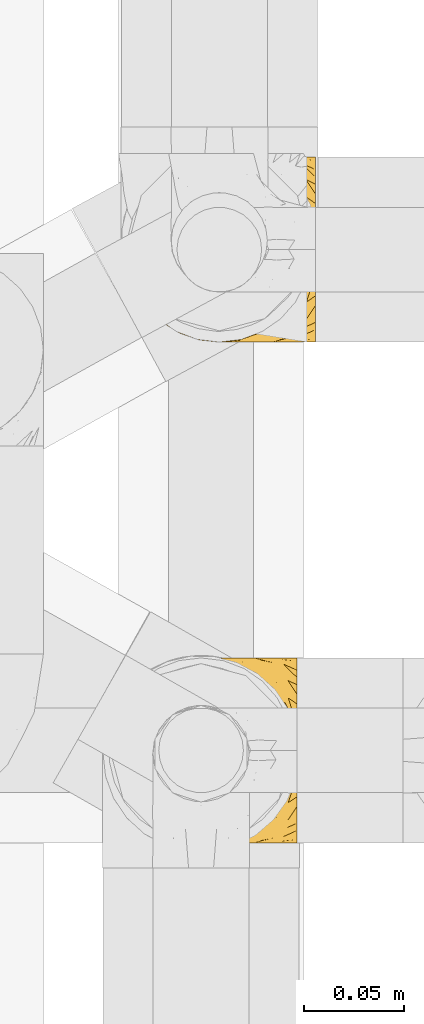
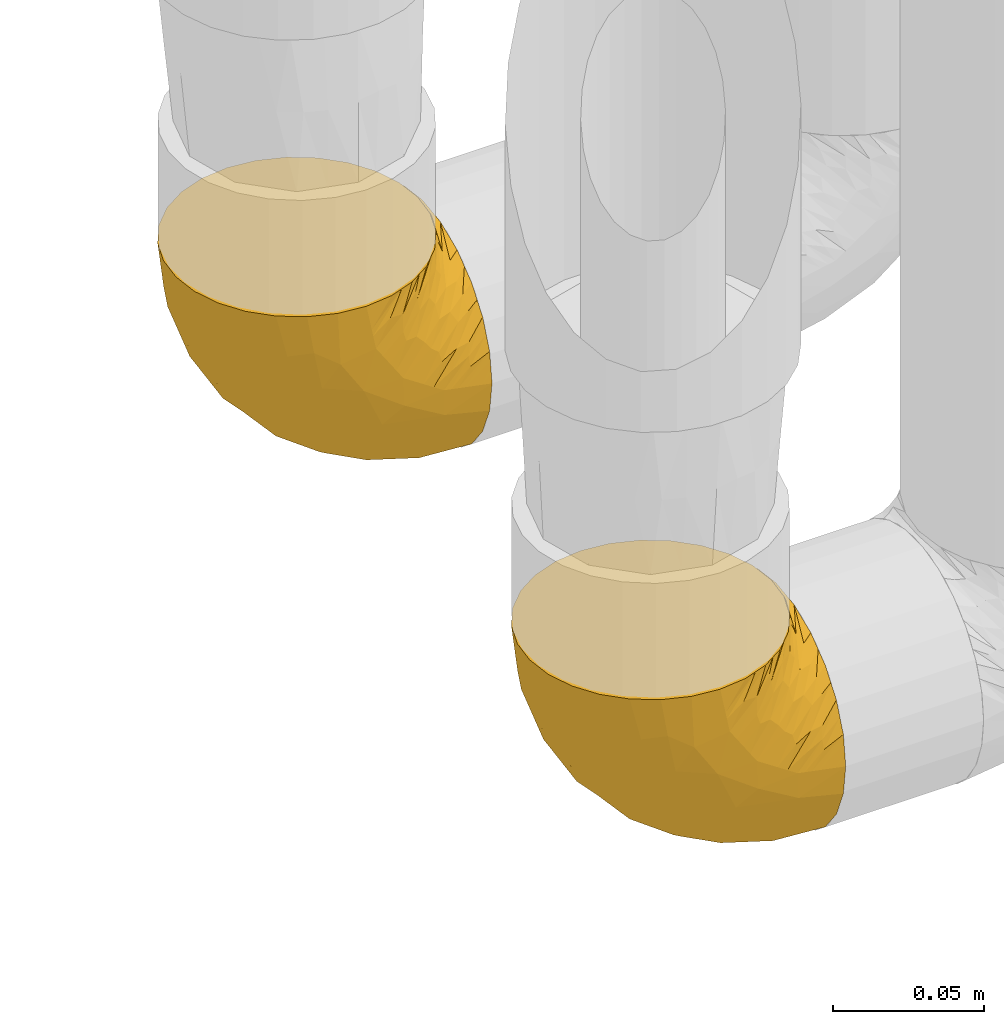
# One storey, part 174 of 827: 2 coverings.
"""IFC2X3 building model written with IfcOpenShell, lengths in millimetres."""

from ifc_helpers import new_model, entity, si_unit, converted_unit, derived_unit, direction, frame, origin, place, context, subcontext, project, spatial, faceted_brep, element, save


model = new_model("IFC2X3")

# Units and contexts
model_context = context("Model", 3, precision=0.01, world=origin(), true_north=direction((6.12303176911189e-17, 1.0)))
body_context = subcontext(model_context, "Body", "Model", "MODEL_VIEW")
ifc_project = project(units=[si_unit("LENGTHUNIT", "METRE", prefix="MILLI"), si_unit("AREAUNIT", "SQUARE_METRE"), si_unit("VOLUMEUNIT", "CUBIC_METRE"), converted_unit("PLANEANGLEUNIT", "DEGREE", entity("IfcRatioMeasure", 0.0174532925199433), si_unit("PLANEANGLEUNIT", "RADIAN"), dimensions=[0, 0, 0, 0, 0, 0, 0]), si_unit("MASSUNIT", "GRAM", prefix="KILO"), derived_unit("MASSDENSITYUNIT", [(si_unit("MASSUNIT", "GRAM", prefix="KILO"), 1), (si_unit("LENGTHUNIT", "METRE"), -3)]), derived_unit("MOMENTOFINERTIAUNIT", [(si_unit("LENGTHUNIT", "METRE"), 4)]), si_unit("TIMEUNIT", "SECOND"), si_unit("FREQUENCYUNIT", "HERTZ"), si_unit("THERMODYNAMICTEMPERATUREUNIT", "DEGREE_CELSIUS"), derived_unit("THERMALTRANSMITTANCEUNIT", [(si_unit("MASSUNIT", "GRAM", prefix="KILO"), 1), (si_unit("THERMODYNAMICTEMPERATUREUNIT", "KELVIN"), -1), (si_unit("TIMEUNIT", "SECOND"), -3)]), derived_unit("VOLUMETRICFLOWRATEUNIT", [(si_unit("LENGTHUNIT", "METRE"), 3), (si_unit("TIMEUNIT", "SECOND"), -1)]), derived_unit("MASSFLOWRATEUNIT", [(si_unit("MASSUNIT", "GRAM", prefix="KILO"), 1), (si_unit("TIMEUNIT", "SECOND"), -1)]), derived_unit("ROTATIONALFREQUENCYUNIT", [(si_unit("TIMEUNIT", "SECOND"), -1)]), si_unit("ELECTRICCURRENTUNIT", "AMPERE"), si_unit("ELECTRICVOLTAGEUNIT", "VOLT"), si_unit("POWERUNIT", "WATT"), si_unit("FORCEUNIT", "NEWTON", prefix="KILO"), si_unit("ILLUMINANCEUNIT", "LUX"), si_unit("LUMINOUSFLUXUNIT", "LUMEN"), si_unit("LUMINOUSINTENSITYUNIT", "CANDELA"), derived_unit("USERDEFINED", [(si_unit("MASSUNIT", "GRAM", prefix="KILO"), -1), (si_unit("LENGTHUNIT", "METRE"), -2), (si_unit("TIMEUNIT", "SECOND"), 3), (si_unit("LUMINOUSFLUXUNIT", "LUMEN"), 1)]), derived_unit("LINEARVELOCITYUNIT", [(si_unit("LENGTHUNIT", "METRE"), 1), (si_unit("TIMEUNIT", "SECOND"), -1)]), si_unit("PRESSUREUNIT", "PASCAL"), derived_unit("USERDEFINED", [(si_unit("LENGTHUNIT", "METRE"), -2), (si_unit("MASSUNIT", "GRAM", prefix="KILO"), 1), (si_unit("TIMEUNIT", "SECOND"), -2)]), derived_unit("LINEARFORCEUNIT", [(si_unit("MASSUNIT", "GRAM", prefix="KILO"), 1), (si_unit("LENGTHUNIT", "METRE"), 1), (si_unit("TIMEUNIT", "SECOND"), -2), (si_unit("LENGTHUNIT", "METRE"), -1)]), derived_unit("PLANARFORCEUNIT", [(si_unit("MASSUNIT", "GRAM", prefix="KILO"), 1), (si_unit("LENGTHUNIT", "METRE"), 1), (si_unit("TIMEUNIT", "SECOND"), -2), (si_unit("LENGTHUNIT", "METRE"), -2)])], contexts=[model_context])

# Site, building, storey
site_placement = place(None, origin())
site = spatial("IfcSite", under=ifc_project, at=site_placement, CompositionType="ELEMENT")
building_placement = place(site_placement, origin())
building = spatial("IfcBuilding", under=site, at=building_placement, CompositionType="ELEMENT")
storey_placement = place(building_placement, frame((0.0, 0.0, 28200.0)))
storey = spatial("IfcBuildingStorey", under=building, at=storey_placement, Name="08", CompositionType="ELEMENT", Elevation=28200.0)

# Coverings
covering_1_placement = place(storey_placement, frame((35677.24, 12708.37, 352.2)))
element("IfcCovering", 1, at=covering_1_placement, inside=storey, Name=":ADSK_", ObjectType=":ADSK_", PredefinedType="INSULATION", context=body_context, shape_type="Brep", body=[
    faceted_brep([(18.98, 83.91, 95.8), (11.67, 76.59, 95.8), (6.17, 67.83, 95.8), (2.75, 58.07, 95.8), (1.6, 47.8, 95.8), (2.75, 37.51, 95.8), (6.17, 27.74, 95.8), (11.68, 18.98, 95.8), (19.0, 11.67, 95.8), (27.76, 6.17, 95.8), (37.52, 2.75, 95.8), (47.8, 1.6, 95.8), (51.94, 2.06, 95.8), (55.01, 2.41, 95.8), (58.08, 2.75, 95.8), (62.96, 4.46, 95.8), (67.85, 6.17, 95.8), (72.23, 8.93, 95.8), (76.61, 11.68, 95.8), (80.26, 15.34, 95.8), (83.92, 19.0, 95.8), (89.42, 27.76, 95.8), (91.13, 32.64, 95.8), (92.84, 37.52, 95.8), (94.0, 47.8, 95.8), (92.84, 58.08, 95.8), (91.13, 62.96, 95.8), (89.42, 67.85, 95.8), (83.91, 76.61, 95.8), (80.25, 80.26, 95.8), (76.59, 83.92, 95.8), (72.21, 86.67, 95.8), (67.83, 89.42, 95.8), (62.95, 91.13, 95.8), (58.07, 92.84, 95.8), (55.0, 93.18, 95.8), (51.94, 93.53, 95.8), (47.8, 94.0, 95.8), (37.51, 92.84, 95.8), (27.74, 89.42, 95.8), (95.8, 47.8, 94.0), (95.8, 35.84, 92.42), (95.8, 24.7, 87.81), (95.8, 19.91, 84.13), (95.8, 15.13, 80.46), (95.8, 11.46, 75.68), (95.8, 7.78, 70.9), (95.8, 5.48, 65.32), (95.8, 3.17, 59.75), (95.8, 2.69, 56.14), (95.8, 2.42, 54.06), (95.8, 2.14, 51.97), (95.8, 1.6, 47.8), (95.8, 3.17, 35.84), (95.8, 7.78, 24.7), (95.8, 15.13, 15.13), (95.8, 24.7, 7.78), (95.8, 35.84, 3.17), (95.8, 47.8, 1.6), (95.8, 59.75, 3.17), (95.8, 70.9, 7.78), (95.8, 80.46, 15.13), (95.8, 87.81, 24.7), (95.8, 92.42, 35.84), (95.8, 94.0, 47.8), (95.8, 93.45, 51.97), (95.8, 92.9, 56.14), (95.8, 92.42, 59.75), (95.8, 90.11, 65.32), (95.8, 87.81, 70.9), (95.8, 84.13, 75.68), (95.8, 80.46, 80.46), (95.8, 75.68, 84.13), (95.8, 70.9, 87.81), (95.8, 59.75, 92.42), (60.58, 71.98, 15.84), (74.11, 63.6, 6.99), (51.59, 59.72, 14.39), (66.69, 47.8, 6.21), (76.19, 55.16, 4.26), (84.43, 47.8, 3.39), (31.2, 63.76, 31.2), (42.88, 72.22, 26.47), (79.41, 74.18, 11.44), (60.7, 92.52, 47.66), (61.85, 94.0, 61.85), (65.75, 94.0, 59.25), (69.64, 94.0, 56.65), (73.53, 94.0, 54.05), (77.43, 94.0, 51.45), (74.59, 82.14, 19.8), (54.72, 80.34, 26.22), (64.18, 87.52, 31.58), (37.94, 79.59, 38.36), (25.89, 78.25, 51.54), (34.73, 85.01, 51.6), (42.89, 90.25, 55.97), (49.83, 93.2, 62.88), (48.58, 87.23, 41.35), (22.41, 85.55, 82.24), (78.69, 93.0, 40.88), (81.64, 89.31, 29.0), (6.22, 61.31, 74.06), (12.11, 56.86, 54.53), (14.81, 68.34, 57.98), (21.61, 65.71, 43.81), (22.41, 56.99, 38.22), (30.12, 72.15, 38.33), (10.01, 70.34, 74.76), (15.36, 78.36, 76.85), (3.39, 47.8, 84.43), (19.59, 47.8, 40.43), (30.01, 47.8, 30.01), (41.19, 93.06, 78.67), (48.54, 94.0, 92.06), (49.28, 94.0, 88.32), (49.82, 94.0, 85.6), (50.37, 94.0, 82.88), (50.91, 94.0, 80.15), (51.45, 94.0, 77.43), (31.61, 89.88, 76.36), (80.15, 94.0, 50.91), (82.88, 94.0, 50.37), (85.6, 94.0, 49.82), (88.32, 94.0, 49.28), (90.19, 94.0, 48.91), (92.06, 94.0, 48.54), (6.21, 47.8, 66.69), (54.05, 94.0, 73.53), (56.65, 94.0, 69.64), (59.25, 94.0, 65.75), (24.66, 83.7, 66.13), (40.43, 47.8, 19.59), (35.17, 55.9, 24.64), (12.9, 47.8, 53.56), (53.56, 47.8, 12.9), (85.34, 81.75, 82.81), (78.44, 86.43, 81.22), (84.37, 79.8, 86.57), (89.05, 69.84, 92.75), (82.76, 79.5, 89.68), (86.31, 88.08, 72.26), (83.73, 91.6, 64.73), (77.31, 92.93, 62.45), (87.78, 92.43, 60.63), (87.91, 93.24, 56.91), (81.29, 93.36, 58.14), (93.97, 57.25, 93.7), (70.76, 89.41, 83.4), (63.67, 92.89, 75.54), (62.62, 92.66, 79.46), (90.64, 79.58, 82.28), (84.08, 86.51, 76.25), (76.28, 86.29, 84.69), (77.45, 83.91, 90.18), (88.72, 90.94, 65.12), (71.28, 91.94, 71.71), (68.09, 91.98, 75.21), (91.07, 82.79, 78.6), (57.47, 93.16, 87.27), (70.34, 88.76, 87.92), (91.35, 73.94, 86.94), (62.99, 91.89, 86.1), (94.52, 47.8, 94.52), (76.47, 92.22, 66.23), (69.96, 88.56, 91.08), (89.86, 87.72, 71.77), (78.94, 88.33, 76.21), (73.51, 92.18, 68.59), (89.62, 71.78, 89.94), (84.09, 9.09, 76.25), (86.3, 7.51, 72.26), (91.06, 12.8, 78.6), (88.32, 1.6, 49.28), (92.06, 1.6, 48.54), (82.88, 1.6, 50.37), (85.6, 1.6, 49.82), (93.97, 38.35, 93.7), (89.63, 23.84, 89.95), (50.37, 1.6, 82.88), (49.82, 1.6, 85.6), (48.54, 1.6, 92.06), (49.28, 1.6, 88.32), (82.77, 16.1, 89.68), (70.36, 6.84, 87.92), (77.31, 2.66, 62.45), (76.47, 3.37, 66.24), (69.64, 1.6, 56.65), (65.75, 1.6, 59.25), (87.78, 3.16, 60.63), (87.91, 2.35, 56.91), (89.06, 25.77, 92.76), (90.65, 16.02, 82.28), (85.35, 13.85, 82.81), (73.53, 1.6, 54.05), (77.43, 1.6, 51.45), (81.29, 2.23, 58.14), (77.46, 11.69, 90.18), (76.29, 9.31, 84.7), (57.47, 2.43, 87.25), (63.71, 2.71, 75.58), (68.11, 3.61, 75.2), (70.77, 6.18, 83.39), (71.31, 3.66, 71.7), (78.46, 9.17, 81.22), (69.52, 6.77, 90.73), (62.64, 2.93, 79.47), (91.35, 21.66, 86.94), (59.25, 1.6, 65.75), (84.6, 16.09, 86.75), (62.98, 3.7, 86.08), (51.45, 1.6, 77.43), (54.05, 1.6, 73.53), (56.65, 1.6, 69.64), (83.73, 3.99, 64.73), (80.15, 1.6, 50.91), (88.72, 4.65, 65.12), (61.85, 1.6, 61.85), (73.56, 3.43, 68.62), (78.96, 7.27, 76.22), (91.36, 9.46, 74.03), (50.91, 1.6, 80.15), (62.87, 2.4, 49.81), (76.19, 40.43, 4.26), (73.57, 13.57, 19.95), (56.07, 11.3, 30.61), (49.77, 18.65, 25.71), (44.73, 27.26, 22.43), (60.58, 23.61, 15.85), (47.64, 3.07, 60.69), (78.32, 2.69, 40.49), (51.59, 35.87, 14.39), (74.11, 31.99, 6.99), (76.04, 6.71, 29.56), (79.41, 21.41, 11.45), (14.82, 27.24, 57.98), (6.22, 34.26, 74.06), (12.12, 38.73, 54.52), (23.51, 26.97, 43.47), (31.2, 31.83, 31.2), (34.96, 23.4, 33.27), (33.86, 6.91, 64.26), (38.94, 3.4, 74.29), (30.23, 5.84, 80.41), (35.17, 39.69, 24.64), (15.85, 17.6, 73.62), (22.59, 10.38, 78.98), (21.56, 20.6, 53.69), (55.94, 5.36, 42.86), (20.67, 35.73, 41.67), (9.19, 24.84, 79.66), (25.79, 13.87, 58.41), (41.16, 9.06, 47.11), (37.95, 15.99, 38.37)], [[[0, 1, 2, 3, 4, 5, 6, 7, 8, 9, 10, 11, 12, 13, 14, 15, 16, 17, 18, 19, 20, 21, 22, 23, 24, 25, 26, 27, 28, 29, 30, 31, 32, 33, 34, 35, 36, 37, 38, 39]], [[40, 41, 42, 43, 44, 45, 46, 47, 48, 49, 50, 51, 52, 53, 54, 55, 56, 57, 58, 59, 60, 61, 62, 63, 64, 65, 66, 67, 68, 69, 70, 71, 72, 73, 74]], [[75, 76, 77]], [[78, 79, 80]], [[77, 81, 82]], [[76, 75, 83]], [[84, 85, 86, 87, 88, 89]], [[90, 91, 92]], [[76, 60, 59]], [[93, 94, 95]], [[90, 62, 61]], [[83, 61, 60]], [[96, 97, 84]], [[98, 93, 95]], [[0, 39, 99]], [[100, 84, 89]], [[62, 101, 63]], [[2, 102, 3]], [[92, 84, 100]], [[103, 102, 104]], [[103, 105, 106]], [[93, 107, 94]], [[1, 108, 2]], [[92, 101, 90]], [[108, 1, 109]], [[102, 110, 3]], [[93, 82, 107]], [[102, 108, 104]], [[111, 106, 112]], [[109, 0, 99]], [[113, 37, 114, 115, 116, 117, 118, 119]], [[120, 38, 113]], [[100, 89, 121, 122, 123, 124, 125, 126, 64]], [[127, 102, 103]], [[97, 119, 128, 129, 130, 85]], [[99, 120, 131]], [[132, 133, 77]], [[59, 80, 79]], [[1, 0, 109]], [[98, 84, 92]], [[94, 109, 131]], [[120, 39, 38]], [[93, 91, 82]], [[104, 94, 105]], [[97, 113, 119]], [[95, 120, 96]], [[83, 90, 61]], [[91, 93, 98]], [[64, 63, 100]], [[100, 63, 101]], [[77, 76, 79]], [[133, 106, 81]], [[84, 97, 85]], [[113, 96, 120]], [[113, 97, 96]], [[37, 113, 38]], [[110, 102, 127]], [[110, 4, 3]], [[103, 111, 134, 127]], [[90, 75, 91]], [[82, 81, 107]], [[91, 75, 82]], [[77, 82, 75]], [[76, 83, 60]], [[90, 83, 75]], [[105, 107, 81]], [[94, 131, 95]], [[105, 94, 107]], [[109, 94, 104]], [[120, 95, 131]], [[98, 95, 96]], [[84, 98, 96]], [[98, 92, 91]], [[106, 105, 81]], [[103, 104, 105]], [[112, 106, 133]], [[103, 106, 111]], [[112, 133, 132]], [[81, 77, 133]], [[77, 78, 135, 132]], [[120, 99, 39]], [[109, 99, 131]], [[59, 58, 80]], [[59, 79, 76]], [[90, 101, 62]], [[100, 101, 92]], [[2, 108, 102]], [[109, 104, 108]], [[78, 77, 79]], [[136, 137, 138]], [[27, 139, 140]], [[141, 142, 143]], [[144, 145, 121]], [[146, 89, 88]], [[147, 139, 25]], [[148, 149, 150]], [[136, 151, 152]], [[147, 40, 74]], [[24, 147, 25]], [[140, 153, 154]], [[33, 116, 34]], [[73, 72, 151]], [[114, 37, 36, 35, 34, 116, 115]], [[146, 155, 144]], [[156, 85, 130]], [[157, 149, 148]], [[151, 158, 152]], [[117, 33, 159]], [[29, 154, 160]], [[161, 74, 73]], [[162, 128, 119]], [[66, 65, 64, 126, 125, 124, 123, 122, 67]], [[163, 147, 24]], [[27, 140, 28]], [[149, 129, 150]], [[139, 27, 26, 25]], [[68, 144, 69]], [[129, 128, 150]], [[164, 87, 86]], [[130, 129, 149]], [[122, 145, 67]], [[154, 153, 148]], [[162, 119, 159]], [[165, 30, 160]], [[150, 160, 148]], [[128, 162, 150]], [[30, 165, 31]], [[145, 144, 68]], [[89, 146, 144]], [[87, 164, 143]], [[166, 155, 142]], [[88, 87, 143]], [[162, 160, 150]], [[160, 30, 29]], [[154, 29, 28]], [[140, 154, 28]], [[160, 154, 148]], [[140, 137, 153]], [[157, 148, 153]], [[156, 130, 157]], [[153, 137, 157]], [[157, 137, 156]], [[167, 137, 136]], [[168, 85, 156]], [[152, 168, 167]], [[167, 168, 156]], [[164, 152, 141]], [[71, 158, 72]], [[152, 167, 136]], [[88, 142, 146]], [[144, 155, 69]], [[146, 142, 155]], [[70, 166, 71]], [[142, 141, 166]], [[70, 69, 155]], [[141, 158, 71]], [[161, 73, 151]], [[138, 137, 140]], [[161, 136, 169]], [[136, 161, 151]], [[74, 161, 169]], [[152, 158, 141]], [[151, 72, 158]], [[168, 152, 164]], [[137, 167, 156]], [[164, 86, 168]], [[85, 168, 86]], [[116, 33, 117]], [[130, 149, 157]], [[67, 145, 68]], [[121, 89, 144]], [[145, 122, 121]], [[40, 147, 163]], [[169, 147, 74]], [[159, 33, 32]], [[162, 159, 32]], [[159, 119, 118, 117]], [[139, 147, 169]], [[139, 169, 138]], [[162, 32, 31]], [[141, 143, 164]], [[88, 143, 142]], [[71, 166, 141]], [[155, 166, 70]], [[139, 138, 140]], [[169, 136, 138]], [[160, 162, 165]], [[162, 31, 165]], [[170, 171, 172]], [[173, 174, 52, 51, 50, 49, 48, 175, 176]], [[177, 178, 41]], [[179, 15, 180]], [[12, 11, 181, 182, 180, 14, 13]], [[183, 21, 20]], [[19, 18, 184]], [[185, 186, 187]], [[186, 188, 187]], [[43, 172, 44]], [[189, 190, 47]], [[23, 22, 21, 191]], [[170, 192, 193]], [[40, 163, 177]], [[194, 195, 196]], [[24, 23, 177]], [[197, 198, 183]], [[199, 15, 179]], [[47, 46, 189]], [[200, 201, 202]], [[201, 203, 204]], [[205, 206, 184]], [[207, 41, 178]], [[16, 15, 199]], [[14, 180, 15]], [[202, 201, 198]], [[208, 201, 200]], [[163, 24, 177]], [[48, 47, 190]], [[196, 195, 189]], [[197, 184, 202]], [[204, 193, 209]], [[210, 211, 212]], [[206, 212, 213]], [[205, 17, 210]], [[184, 206, 202]], [[210, 212, 206]], [[185, 194, 214]], [[189, 215, 190]], [[216, 45, 214]], [[186, 171, 170]], [[189, 216, 196]], [[197, 20, 19]], [[194, 185, 187]], [[197, 183, 20]], [[184, 197, 19]], [[197, 202, 198]], [[206, 200, 202]], [[204, 183, 198]], [[201, 208, 203]], [[203, 208, 217]], [[204, 198, 201]], [[217, 188, 218]], [[193, 219, 170]], [[171, 186, 185]], [[170, 218, 186]], [[170, 219, 218]], [[42, 207, 192]], [[171, 220, 172]], [[216, 189, 46]], [[214, 194, 196]], [[44, 220, 45]], [[214, 196, 216]], [[216, 46, 45]], [[214, 45, 220]], [[192, 43, 42]], [[204, 203, 219]], [[207, 193, 192]], [[209, 193, 178]], [[41, 207, 42]], [[193, 207, 178]], [[43, 192, 172]], [[170, 172, 192]], [[204, 219, 193]], [[219, 203, 218]], [[217, 218, 203]], [[188, 186, 218]], [[206, 213, 200]], [[208, 200, 213]], [[199, 210, 16]], [[215, 189, 195]], [[215, 175, 190]], [[175, 48, 190]], [[199, 179, 221, 211]], [[210, 199, 211]], [[23, 191, 177]], [[40, 177, 41]], [[178, 177, 191]], [[21, 183, 191]], [[209, 191, 183]], [[205, 18, 17]], [[17, 16, 210]], [[171, 185, 214]], [[172, 220, 44]], [[214, 220, 171]], [[191, 209, 178]], [[204, 209, 183]], [[206, 205, 210]], [[18, 205, 184]], [[222, 195, 194, 187, 188, 217]], [[57, 223, 80]], [[224, 225, 226]], [[226, 227, 228]], [[229, 217, 208, 213, 212, 211]], [[230, 52, 174, 173, 176, 175, 215, 195]], [[231, 232, 228]], [[231, 78, 223]], [[223, 57, 232]], [[224, 233, 225]], [[233, 54, 53]], [[234, 232, 56]], [[56, 55, 234]], [[234, 224, 228]], [[235, 236, 237]], [[224, 55, 54]], [[238, 239, 240]], [[52, 230, 53]], [[241, 242, 243]], [[227, 244, 231]], [[11, 10, 242]], [[236, 6, 5]], [[7, 245, 8]], [[8, 246, 9]], [[238, 247, 235]], [[222, 229, 248]], [[242, 211, 221, 179, 180, 182, 181, 11]], [[233, 53, 230]], [[111, 112, 249]], [[250, 6, 236]], [[246, 251, 241]], [[6, 250, 7]], [[127, 236, 110]], [[248, 229, 252]], [[246, 8, 245]], [[235, 245, 250]], [[236, 5, 110]], [[235, 249, 238]], [[237, 236, 127]], [[243, 9, 246]], [[252, 229, 241]], [[56, 232, 57]], [[222, 230, 195]], [[225, 248, 252]], [[248, 233, 230]], [[54, 233, 224]], [[231, 228, 227]], [[244, 132, 231]], [[248, 225, 233]], [[226, 225, 253]], [[235, 250, 236]], [[245, 7, 250]], [[251, 246, 245]], [[243, 246, 241]], [[247, 245, 235]], [[252, 251, 253]], [[229, 222, 217]], [[230, 222, 248]], [[5, 4, 110]], [[237, 127, 134, 111]], [[238, 249, 239]], [[224, 234, 55]], [[232, 234, 228]], [[242, 241, 229]], [[10, 9, 243]], [[211, 242, 229]], [[10, 243, 242]], [[80, 223, 78]], [[80, 58, 57]], [[231, 223, 232]], [[227, 240, 239]], [[224, 226, 228]], [[240, 226, 253]], [[227, 239, 244]], [[226, 240, 227]], [[251, 247, 253]], [[240, 253, 247]], [[249, 235, 237]], [[237, 111, 249]], [[112, 132, 244]], [[112, 244, 249]], [[78, 231, 132, 135]], [[249, 244, 239]], [[247, 238, 240]], [[245, 247, 251]], [[251, 252, 241]], [[225, 252, 253]]]),
])
covering_2_placement = place(storey_placement, frame((35686.34, 12958.41, 352.2)))
element("IfcCovering", 2, at=covering_2_placement, inside=storey, Name=":ADSK_", ObjectType=":ADSK_", PredefinedType="INSULATION", context=body_context, shape_type="Brep", body=[
    faceted_brep([(18.98, 83.91, 95.8), (11.67, 76.59, 95.8), (6.17, 67.83, 95.8), (2.75, 58.07, 95.8), (1.6, 47.8, 95.8), (2.75, 37.51, 95.8), (6.17, 27.74, 95.8), (11.68, 18.98, 95.8), (19.0, 11.67, 95.8), (27.76, 6.17, 95.8), (37.52, 2.75, 95.8), (47.8, 1.6, 95.8), (51.94, 2.06, 95.8), (55.01, 2.41, 95.8), (58.08, 2.75, 95.8), (62.96, 4.46, 95.8), (67.85, 6.17, 95.8), (72.23, 8.93, 95.8), (76.61, 11.68, 95.8), (80.26, 15.34, 95.8), (83.92, 19.0, 95.8), (89.42, 27.76, 95.8), (91.13, 32.64, 95.8), (92.84, 37.52, 95.8), (94.0, 47.8, 95.8), (92.84, 58.08, 95.8), (91.13, 62.96, 95.8), (89.42, 67.85, 95.8), (83.91, 76.61, 95.8), (80.25, 80.26, 95.8), (76.59, 83.92, 95.8), (72.21, 86.67, 95.8), (67.83, 89.42, 95.8), (62.95, 91.13, 95.8), (58.07, 92.84, 95.8), (55.0, 93.18, 95.8), (51.94, 93.53, 95.8), (47.8, 94.0, 95.8), (37.51, 92.84, 95.8), (27.74, 89.42, 95.8), (95.8, 47.8, 94.0), (95.8, 35.84, 92.42), (95.8, 24.7, 87.81), (95.8, 19.91, 84.13), (95.8, 15.13, 80.46), (95.8, 11.46, 75.68), (95.8, 7.78, 70.9), (95.8, 5.48, 65.32), (95.8, 3.17, 59.75), (95.8, 2.69, 56.14), (95.8, 2.42, 54.06), (95.8, 2.14, 51.97), (95.8, 1.6, 47.8), (95.8, 3.17, 35.84), (95.8, 7.78, 24.7), (95.8, 15.13, 15.13), (95.8, 24.7, 7.78), (95.8, 35.84, 3.17), (95.8, 47.8, 1.6), (95.8, 59.75, 3.17), (95.8, 70.9, 7.78), (95.8, 80.46, 15.13), (95.8, 87.81, 24.7), (95.8, 92.42, 35.84), (95.8, 94.0, 47.8), (95.8, 93.45, 51.97), (95.8, 92.9, 56.14), (95.8, 92.42, 59.75), (95.8, 90.11, 65.32), (95.8, 87.81, 70.9), (95.8, 84.13, 75.68), (95.8, 80.46, 80.46), (95.8, 75.68, 84.13), (95.8, 70.9, 87.81), (95.8, 59.75, 92.42), (60.58, 71.98, 15.84), (74.11, 63.6, 6.99), (51.59, 59.72, 14.39), (66.69, 47.8, 6.21), (76.19, 55.16, 4.26), (84.43, 47.8, 3.39), (31.2, 63.76, 31.2), (42.88, 72.22, 26.47), (79.41, 74.18, 11.44), (60.7, 92.52, 47.66), (61.85, 94.0, 61.85), (65.75, 94.0, 59.25), (69.64, 94.0, 56.65), (73.53, 94.0, 54.05), (77.43, 94.0, 51.45), (74.59, 82.14, 19.8), (54.72, 80.34, 26.22), (64.18, 87.52, 31.58), (37.94, 79.59, 38.36), (25.89, 78.25, 51.54), (34.73, 85.01, 51.6), (42.89, 90.25, 55.97), (49.83, 93.2, 62.88), (48.58, 87.23, 41.35), (22.41, 85.55, 82.24), (78.69, 93.0, 40.88), (81.64, 89.31, 29.0), (6.22, 61.31, 74.06), (12.11, 56.86, 54.53), (14.81, 68.34, 57.98), (21.61, 65.71, 43.81), (22.41, 56.99, 38.22), (30.12, 72.15, 38.33), (10.01, 70.34, 74.76), (15.36, 78.36, 76.85), (3.39, 47.8, 84.43), (19.59, 47.8, 40.43), (30.01, 47.8, 30.01), (41.19, 93.06, 78.67), (48.54, 94.0, 92.06), (49.28, 94.0, 88.32), (49.82, 94.0, 85.6), (50.37, 94.0, 82.88), (50.91, 94.0, 80.15), (51.45, 94.0, 77.43), (31.61, 89.88, 76.36), (80.15, 94.0, 50.91), (82.88, 94.0, 50.37), (85.6, 94.0, 49.82), (88.32, 94.0, 49.28), (90.19, 94.0, 48.91), (92.06, 94.0, 48.54), (6.21, 47.8, 66.69), (54.05, 94.0, 73.53), (56.65, 94.0, 69.64), (59.25, 94.0, 65.75), (24.66, 83.7, 66.13), (40.43, 47.8, 19.59), (35.17, 55.9, 24.64), (12.9, 47.8, 53.56), (53.56, 47.8, 12.9), (85.34, 81.75, 82.81), (78.44, 86.43, 81.22), (84.37, 79.8, 86.57), (89.05, 69.84, 92.75), (82.76, 79.5, 89.68), (86.31, 88.08, 72.26), (83.73, 91.6, 64.73), (77.31, 92.93, 62.45), (87.78, 92.43, 60.63), (87.91, 93.24, 56.91), (81.29, 93.36, 58.14), (93.97, 57.25, 93.7), (70.76, 89.41, 83.4), (63.67, 92.89, 75.54), (62.62, 92.66, 79.46), (90.64, 79.58, 82.28), (84.08, 86.51, 76.25), (76.28, 86.29, 84.69), (77.45, 83.91, 90.18), (88.72, 90.94, 65.12), (71.28, 91.94, 71.71), (68.09, 91.98, 75.21), (91.07, 82.79, 78.6), (57.47, 93.16, 87.27), (70.34, 88.76, 87.92), (91.35, 73.94, 86.94), (62.99, 91.89, 86.1), (94.52, 47.8, 94.52), (76.47, 92.22, 66.23), (69.96, 88.56, 91.08), (89.86, 87.72, 71.77), (78.94, 88.33, 76.21), (73.51, 92.18, 68.59), (89.62, 71.78, 89.94), (84.09, 9.09, 76.25), (86.3, 7.51, 72.26), (91.06, 12.8, 78.6), (88.32, 1.6, 49.28), (92.06, 1.6, 48.54), (82.88, 1.6, 50.37), (85.6, 1.6, 49.82), (93.97, 38.35, 93.7), (89.63, 23.84, 89.95), (50.37, 1.6, 82.88), (49.82, 1.6, 85.6), (48.54, 1.6, 92.06), (49.28, 1.6, 88.32), (82.77, 16.1, 89.68), (70.36, 6.84, 87.92), (77.31, 2.66, 62.45), (76.47, 3.37, 66.24), (69.64, 1.6, 56.65), (65.75, 1.6, 59.25), (87.78, 3.16, 60.63), (87.91, 2.35, 56.91), (89.06, 25.77, 92.76), (90.65, 16.02, 82.28), (85.35, 13.85, 82.81), (73.53, 1.6, 54.05), (77.43, 1.6, 51.45), (81.29, 2.23, 58.14), (77.46, 11.69, 90.18), (76.29, 9.31, 84.7), (57.47, 2.43, 87.25), (63.71, 2.71, 75.58), (68.11, 3.61, 75.2), (70.77, 6.18, 83.39), (71.31, 3.66, 71.7), (78.46, 9.17, 81.22), (69.52, 6.77, 90.73), (62.64, 2.93, 79.47), (91.35, 21.66, 86.94), (59.25, 1.6, 65.75), (84.6, 16.09, 86.75), (62.98, 3.7, 86.08), (51.45, 1.6, 77.43), (54.05, 1.6, 73.53), (56.65, 1.6, 69.64), (83.73, 3.99, 64.73), (80.15, 1.6, 50.91), (88.72, 4.65, 65.12), (61.85, 1.6, 61.85), (73.56, 3.43, 68.62), (78.96, 7.27, 76.22), (91.36, 9.46, 74.03), (50.91, 1.6, 80.15), (62.87, 2.4, 49.81), (76.19, 40.43, 4.26), (73.57, 13.57, 19.95), (56.07, 11.3, 30.61), (49.77, 18.65, 25.71), (44.73, 27.26, 22.43), (60.58, 23.61, 15.85), (47.64, 3.07, 60.69), (78.32, 2.69, 40.49), (51.59, 35.87, 14.39), (74.11, 31.99, 6.99), (76.04, 6.71, 29.56), (79.41, 21.41, 11.45), (14.82, 27.24, 57.98), (6.22, 34.26, 74.06), (12.12, 38.73, 54.52), (23.51, 26.97, 43.47), (31.2, 31.83, 31.2), (34.96, 23.4, 33.27), (33.86, 6.91, 64.26), (38.94, 3.4, 74.29), (30.23, 5.84, 80.41), (35.17, 39.69, 24.64), (15.85, 17.6, 73.62), (22.59, 10.38, 78.98), (21.56, 20.6, 53.69), (55.94, 5.36, 42.86), (20.67, 35.73, 41.67), (9.19, 24.84, 79.66), (25.79, 13.87, 58.41), (41.16, 9.06, 47.11), (37.95, 15.99, 38.37)], [[[0, 1, 2, 3, 4, 5, 6, 7, 8, 9, 10, 11, 12, 13, 14, 15, 16, 17, 18, 19, 20, 21, 22, 23, 24, 25, 26, 27, 28, 29, 30, 31, 32, 33, 34, 35, 36, 37, 38, 39]], [[40, 41, 42, 43, 44, 45, 46, 47, 48, 49, 50, 51, 52, 53, 54, 55, 56, 57, 58, 59, 60, 61, 62, 63, 64, 65, 66, 67, 68, 69, 70, 71, 72, 73, 74]], [[75, 76, 77]], [[78, 79, 80]], [[77, 81, 82]], [[76, 75, 83]], [[84, 85, 86, 87, 88, 89]], [[90, 91, 92]], [[76, 60, 59]], [[93, 94, 95]], [[90, 62, 61]], [[83, 61, 60]], [[96, 97, 84]], [[98, 93, 95]], [[0, 39, 99]], [[100, 84, 89]], [[62, 101, 63]], [[2, 102, 3]], [[92, 84, 100]], [[103, 102, 104]], [[103, 105, 106]], [[93, 107, 94]], [[1, 108, 2]], [[92, 101, 90]], [[108, 1, 109]], [[102, 110, 3]], [[93, 82, 107]], [[102, 108, 104]], [[111, 106, 112]], [[109, 0, 99]], [[113, 37, 114, 115, 116, 117, 118, 119]], [[120, 38, 113]], [[100, 89, 121, 122, 123, 124, 125, 126, 64]], [[127, 102, 103]], [[97, 119, 128, 129, 130, 85]], [[99, 120, 131]], [[132, 133, 77]], [[59, 80, 79]], [[1, 0, 109]], [[98, 84, 92]], [[94, 109, 131]], [[120, 39, 38]], [[93, 91, 82]], [[104, 94, 105]], [[97, 113, 119]], [[95, 120, 96]], [[83, 90, 61]], [[91, 93, 98]], [[64, 63, 100]], [[100, 63, 101]], [[77, 76, 79]], [[133, 106, 81]], [[84, 97, 85]], [[113, 96, 120]], [[113, 97, 96]], [[37, 113, 38]], [[110, 102, 127]], [[110, 4, 3]], [[103, 111, 134, 127]], [[90, 75, 91]], [[82, 81, 107]], [[91, 75, 82]], [[77, 82, 75]], [[76, 83, 60]], [[90, 83, 75]], [[105, 107, 81]], [[94, 131, 95]], [[105, 94, 107]], [[109, 94, 104]], [[120, 95, 131]], [[98, 95, 96]], [[84, 98, 96]], [[98, 92, 91]], [[106, 105, 81]], [[103, 104, 105]], [[112, 106, 133]], [[103, 106, 111]], [[112, 133, 132]], [[81, 77, 133]], [[77, 78, 135, 132]], [[120, 99, 39]], [[109, 99, 131]], [[59, 58, 80]], [[59, 79, 76]], [[90, 101, 62]], [[100, 101, 92]], [[2, 108, 102]], [[109, 104, 108]], [[78, 77, 79]], [[136, 137, 138]], [[27, 139, 140]], [[141, 142, 143]], [[144, 145, 121]], [[146, 89, 88]], [[147, 139, 25]], [[148, 149, 150]], [[136, 151, 152]], [[147, 40, 74]], [[24, 147, 25]], [[140, 153, 154]], [[33, 116, 34]], [[73, 72, 151]], [[114, 37, 36, 35, 34, 116, 115]], [[146, 155, 144]], [[156, 85, 130]], [[157, 149, 148]], [[151, 158, 152]], [[117, 33, 159]], [[29, 154, 160]], [[161, 74, 73]], [[162, 128, 119]], [[66, 65, 64, 126, 125, 124, 123, 122, 67]], [[163, 147, 24]], [[27, 140, 28]], [[149, 129, 150]], [[139, 27, 26, 25]], [[68, 144, 69]], [[129, 128, 150]], [[164, 87, 86]], [[130, 129, 149]], [[122, 145, 67]], [[154, 153, 148]], [[162, 119, 159]], [[165, 30, 160]], [[150, 160, 148]], [[128, 162, 150]], [[30, 165, 31]], [[145, 144, 68]], [[89, 146, 144]], [[87, 164, 143]], [[166, 155, 142]], [[88, 87, 143]], [[162, 160, 150]], [[160, 30, 29]], [[154, 29, 28]], [[140, 154, 28]], [[160, 154, 148]], [[140, 137, 153]], [[157, 148, 153]], [[156, 130, 157]], [[153, 137, 157]], [[157, 137, 156]], [[167, 137, 136]], [[168, 85, 156]], [[152, 168, 167]], [[167, 168, 156]], [[164, 152, 141]], [[71, 158, 72]], [[152, 167, 136]], [[88, 142, 146]], [[144, 155, 69]], [[146, 142, 155]], [[70, 166, 71]], [[142, 141, 166]], [[70, 69, 155]], [[141, 158, 71]], [[161, 73, 151]], [[138, 137, 140]], [[161, 136, 169]], [[136, 161, 151]], [[74, 161, 169]], [[152, 158, 141]], [[151, 72, 158]], [[168, 152, 164]], [[137, 167, 156]], [[164, 86, 168]], [[85, 168, 86]], [[116, 33, 117]], [[130, 149, 157]], [[67, 145, 68]], [[121, 89, 144]], [[145, 122, 121]], [[40, 147, 163]], [[169, 147, 74]], [[159, 33, 32]], [[162, 159, 32]], [[159, 119, 118, 117]], [[139, 147, 169]], [[139, 169, 138]], [[162, 32, 31]], [[141, 143, 164]], [[88, 143, 142]], [[71, 166, 141]], [[155, 166, 70]], [[139, 138, 140]], [[169, 136, 138]], [[160, 162, 165]], [[162, 31, 165]], [[170, 171, 172]], [[173, 174, 52, 51, 50, 49, 48, 175, 176]], [[177, 178, 41]], [[179, 15, 180]], [[12, 11, 181, 182, 180, 14, 13]], [[183, 21, 20]], [[19, 18, 184]], [[185, 186, 187]], [[186, 188, 187]], [[43, 172, 44]], [[189, 190, 47]], [[23, 22, 21, 191]], [[170, 192, 193]], [[40, 163, 177]], [[194, 195, 196]], [[24, 23, 177]], [[197, 198, 183]], [[199, 15, 179]], [[47, 46, 189]], [[200, 201, 202]], [[201, 203, 204]], [[205, 206, 184]], [[207, 41, 178]], [[16, 15, 199]], [[14, 180, 15]], [[202, 201, 198]], [[208, 201, 200]], [[163, 24, 177]], [[48, 47, 190]], [[196, 195, 189]], [[197, 184, 202]], [[204, 193, 209]], [[210, 211, 212]], [[206, 212, 213]], [[205, 17, 210]], [[184, 206, 202]], [[210, 212, 206]], [[185, 194, 214]], [[189, 215, 190]], [[216, 45, 214]], [[186, 171, 170]], [[189, 216, 196]], [[197, 20, 19]], [[194, 185, 187]], [[197, 183, 20]], [[184, 197, 19]], [[197, 202, 198]], [[206, 200, 202]], [[204, 183, 198]], [[201, 208, 203]], [[203, 208, 217]], [[204, 198, 201]], [[217, 188, 218]], [[193, 219, 170]], [[171, 186, 185]], [[170, 218, 186]], [[170, 219, 218]], [[42, 207, 192]], [[171, 220, 172]], [[216, 189, 46]], [[214, 194, 196]], [[44, 220, 45]], [[214, 196, 216]], [[216, 46, 45]], [[214, 45, 220]], [[192, 43, 42]], [[204, 203, 219]], [[207, 193, 192]], [[209, 193, 178]], [[41, 207, 42]], [[193, 207, 178]], [[43, 192, 172]], [[170, 172, 192]], [[204, 219, 193]], [[219, 203, 218]], [[217, 218, 203]], [[188, 186, 218]], [[206, 213, 200]], [[208, 200, 213]], [[199, 210, 16]], [[215, 189, 195]], [[215, 175, 190]], [[175, 48, 190]], [[199, 179, 221, 211]], [[210, 199, 211]], [[23, 191, 177]], [[40, 177, 41]], [[178, 177, 191]], [[21, 183, 191]], [[209, 191, 183]], [[205, 18, 17]], [[17, 16, 210]], [[171, 185, 214]], [[172, 220, 44]], [[214, 220, 171]], [[191, 209, 178]], [[204, 209, 183]], [[206, 205, 210]], [[18, 205, 184]], [[222, 195, 194, 187, 188, 217]], [[57, 223, 80]], [[224, 225, 226]], [[226, 227, 228]], [[229, 217, 208, 213, 212, 211]], [[230, 52, 174, 173, 176, 175, 215, 195]], [[231, 232, 228]], [[231, 78, 223]], [[223, 57, 232]], [[224, 233, 225]], [[233, 54, 53]], [[234, 232, 56]], [[56, 55, 234]], [[234, 224, 228]], [[235, 236, 237]], [[224, 55, 54]], [[238, 239, 240]], [[52, 230, 53]], [[241, 242, 243]], [[227, 244, 231]], [[11, 10, 242]], [[236, 6, 5]], [[7, 245, 8]], [[8, 246, 9]], [[238, 247, 235]], [[222, 229, 248]], [[242, 211, 221, 179, 180, 182, 181, 11]], [[233, 53, 230]], [[111, 112, 249]], [[250, 6, 236]], [[246, 251, 241]], [[6, 250, 7]], [[127, 236, 110]], [[248, 229, 252]], [[246, 8, 245]], [[235, 245, 250]], [[236, 5, 110]], [[235, 249, 238]], [[237, 236, 127]], [[243, 9, 246]], [[252, 229, 241]], [[56, 232, 57]], [[222, 230, 195]], [[225, 248, 252]], [[248, 233, 230]], [[54, 233, 224]], [[231, 228, 227]], [[244, 132, 231]], [[248, 225, 233]], [[226, 225, 253]], [[235, 250, 236]], [[245, 7, 250]], [[251, 246, 245]], [[243, 246, 241]], [[247, 245, 235]], [[252, 251, 253]], [[229, 222, 217]], [[230, 222, 248]], [[5, 4, 110]], [[237, 127, 134, 111]], [[238, 249, 239]], [[224, 234, 55]], [[232, 234, 228]], [[242, 241, 229]], [[10, 9, 243]], [[211, 242, 229]], [[10, 243, 242]], [[80, 223, 78]], [[80, 58, 57]], [[231, 223, 232]], [[227, 240, 239]], [[224, 226, 228]], [[240, 226, 253]], [[227, 239, 244]], [[226, 240, 227]], [[251, 247, 253]], [[240, 253, 247]], [[249, 235, 237]], [[237, 111, 249]], [[112, 132, 244]], [[112, 244, 249]], [[78, 231, 132, 135]], [[249, 244, 239]], [[247, 238, 240]], [[245, 247, 251]], [[251, 252, 241]], [[225, 252, 253]]]),
])

save(model, "model.ifc")
